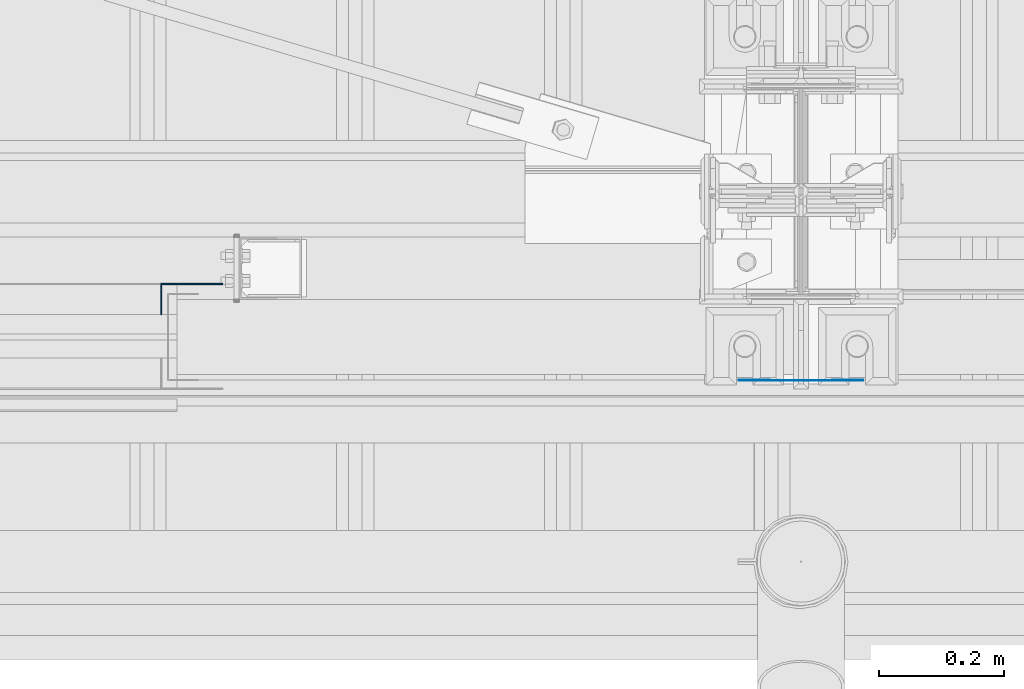
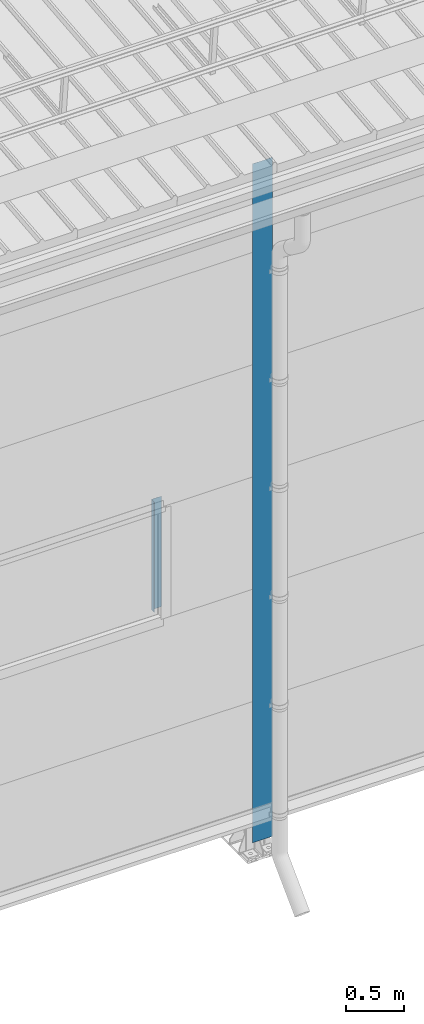
# One storey, part 3 of 709: 2 columns, 2 elements without a shape of their own.
"""IFC4 building model written with IfcOpenShell, lengths in millimetres."""

from ifc_helpers import new_model, si_unit, direction, frame, origin_with_axes, place, context, subcontext, project, spatial, line, indexed_curve, outline, extrude, material, element, aggregate, save


model = new_model("IFC4")

# Units and contexts
model_context = context("Model", 3, precision=0.2, world=origin_with_axes(), true_north=direction((0.0, 1.0)))
body_context = subcontext(model_context, "Body", "Model", "MODEL_VIEW")
ifc_project = project(units=[si_unit("LENGTHUNIT", "METRE", prefix="MILLI"), si_unit("AREAUNIT", "SQUARE_METRE"), si_unit("VOLUMEUNIT", "CUBIC_METRE"), si_unit("MASSUNIT", "GRAM", prefix="KILO"), si_unit("TIMEUNIT", "SECOND"), si_unit("PLANEANGLEUNIT", "RADIAN"), si_unit("SOLIDANGLEUNIT", "STERADIAN"), si_unit("THERMODYNAMICTEMPERATUREUNIT", "DEGREE_CELSIUS"), si_unit("LUMINOUSINTENSITYUNIT", "LUMEN")], contexts=[model_context])

# Site, building, storey
site_placement = place(None, origin_with_axes())
site = spatial("IfcSite", under=ifc_project, at=site_placement, CompositionType="ELEMENT")
building_placement = place(site_placement, origin_with_axes())
building = spatial("IfcBuilding", under=site, at=building_placement, Name="Undefined", CompositionType="ELEMENT")
storey_placement = place(building_placement, origin_with_axes())
storey = spatial("IfcBuildingStorey", under=building, at=storey_placement, Name="Undefined", CompositionType="ELEMENT", Elevation=0.0)

# Assembly, column
assembly_1_placement = place(storey_placement, frame((8975.0, 1.0, 2700.0), z_axis=(0.0, 1.0, 0.0), x_axis=(0.0, 0.0, 1.0)))
assembly_1 = element("IfcElementAssembly", 1, at=assembly_1_placement, inside=storey)
ifc_material = material(Name="Steel_Undefined", Category="STEEL")
column_1_placement = place(assembly_1_placement, origin_with_axes())
column_1 = element("IfcColumn", 2, at=column_1_placement, material=ifc_material, context=body_context, shape_type="SolidModel", body=[
    extrude(outline(indexed_curve([(-25.0, -1.0), (25.0, -1.0), (25.0, 99.0), (23.0, 99.0), (23.0, 1.0), (-25.0, 1.0)], segments=[line(1, 2, 3, 4, 5, 6, 1)])), frame((0.0, 0.0, 0.0), z_axis=(-1.0, 0.0, 0.0), x_axis=(0.0, 0.0, 1.0)), (0.0, 0.0, -1.0), 1170.0),
])
aggregate(assembly_1, [column_1])

assembly_2_placement = place(storey_placement, frame((10000.0, -130.0, 0.0), z_axis=(0.0, 1.0, 0.0), x_axis=(0.0, 0.0, 1.0)))
assembly_2 = element("IfcElementAssembly", 3, at=assembly_2_placement, inside=storey)
column_2_placement = place(assembly_2_placement, origin_with_axes())
column_2 = element("IfcColumn", 4, at=column_2_placement, material=ifc_material, context=body_context, shape_type="SolidModel", body=[
    extrude(outline(indexed_curve([(-0.375, -100.0), (1.245, -100.0), (1.245, -50.0), (0.495, -50.0), (0.495, -99.25), (0.375, -99.25), (0.375, 99.25), (0.495, 99.25), (0.495, 50.0), (1.245, 50.0), (1.245, 100.0), (-0.375, 100.0)], segments=[line(1, 2, 3, 4, 5, 6, 7, 8, 9, 10, 11, 12, 1)])), frame((0.0, 0.0, 0.0), z_axis=(-1.0, 0.0, 0.0), x_axis=(0.0, 0.0, 1.0)), (0.0, 0.0, -1.0), 7196.92297),
])
aggregate(assembly_2, [column_2])

save(model, "model.ifc")
